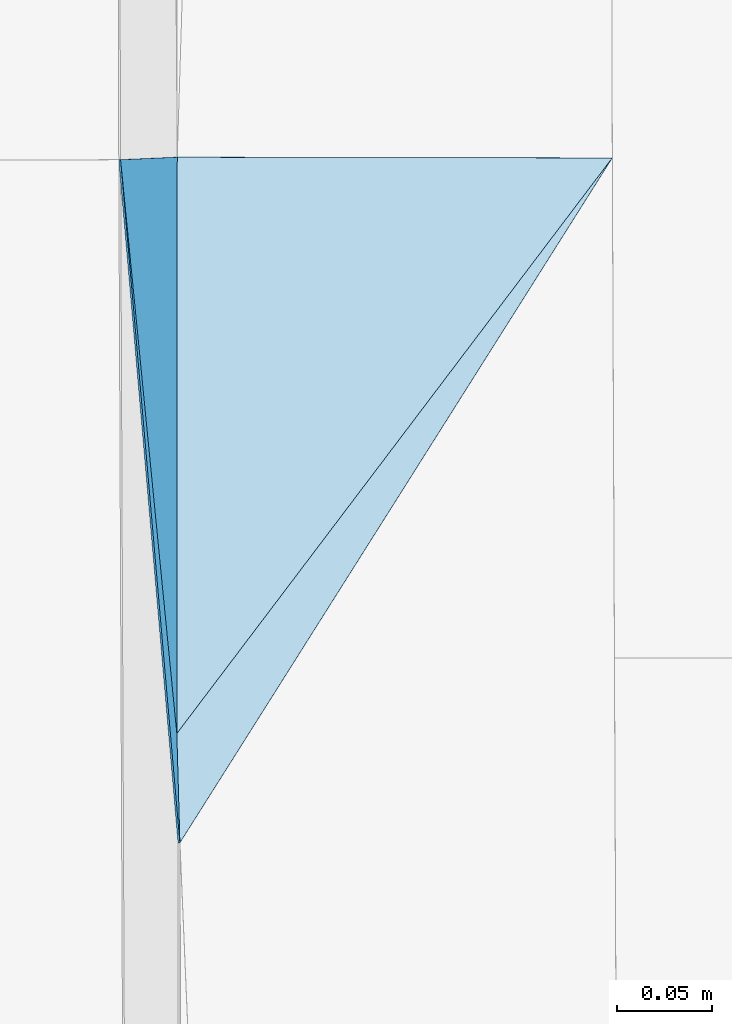
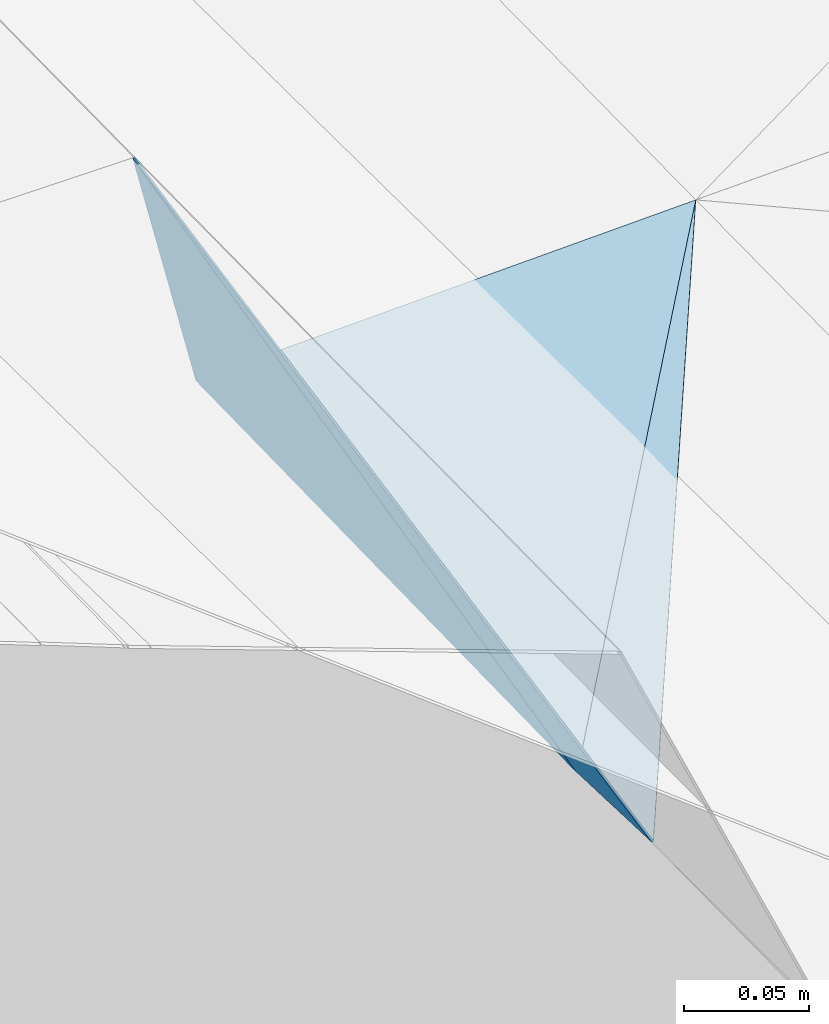
# One storey, part 172 of 275: 4 plates.
"""IFC2X3 building model written with IfcOpenShell, lengths in millimetres."""

import ifcopenshell
import ifcopenshell.guid

model = None  # the IFC model being written
_history = None  # IfcOwnerHistory: only IFC2X3 demands one
_inside = {}  # id of a spatial element -> (the spatial element, [elements in it])
_under = {}  # id of a project, library or spatial element -> (it, [spatial elements below it])
_declared = {}  # id of a project -> (the project, [libraries it declares])
_typed = {}  # id of a type object -> (the type object, [elements of that type])
_made_of = {}  # id of a material, layer set ... -> (it, [elements and type objects made of it])


def new_model(schema):
    """Start an empty IFC model of exactly this schema.

    Asked for "IFC4X3", IfcOpenShell would pick the latest addendum, in which some entities
    have other attributes; the version numbers below select the first issue.
    IFC2X3 requires an IfcOwnerHistory on every rooted entity: one is made here for all.
    """
    global model, _history
    if schema == "IFC4X3":
        model = ifcopenshell.file(schema_version=(4, 3, 0, 0))
    else:
        model = ifcopenshell.file(schema=schema)
    _inside.clear()
    _under.clear()
    _declared.clear()
    _typed.clear()
    _made_of.clear()
    _history = None
    if model.schema == "IFC2X3":
        org = make("IfcOrganization", Name="unknown")
        user = make(
            "IfcPersonAndOrganization",
            ThePerson=make("IfcPerson", FamilyName="unknown"),
            TheOrganization=org,
        )
        app = make(
            "IfcApplication",
            ApplicationDeveloper=org,
            Version="unknown",
            ApplicationFullName="unknown",
            ApplicationIdentifier="unknown",
        )
        _history = make(
            "IfcOwnerHistory",
            OwningUser=user,
            OwningApplication=app,
            ChangeAction="ADDED",
            CreationDate=0,
        )
    return model


def make(cls, **values):
    """One entity of the class cls with the attributes given. An attribute that is None is left unset."""
    return model.create_entity(
        cls, **{name: value for name, value in values.items() if value is not None}
    )


def rooted(cls, **values):
    """An entity with a GlobalId (a new one), such as an element, a storey or a relation."""
    return make(cls, GlobalId=ifcopenshell.guid.new(), OwnerHistory=_history, **values)


def si_unit(unit_type, name, prefix=None):
    """IfcSIUnit, for example si_unit("LENGTHUNIT", "METRE", prefix="MILLI")."""
    return make("IfcSIUnit", UnitType=unit_type, Prefix=prefix, Name=name)


def assignment(units):
    """IfcUnitAssignment: the units of a project."""
    return None if units is None else make("IfcUnitAssignment", Units=units)


def point(xyz):
    """IfcCartesianPoint."""
    return None if xyz is None else make("IfcCartesianPoint", Coordinates=xyz)


def direction(xyz):
    """IfcDirection."""
    return None if xyz is None else make("IfcDirection", DirectionRatios=xyz)


def frame(location, z_axis=None, x_axis=None):
    """IfcAxis2Placement3D, a coordinate frame: its origin and axes. An axis left out is left unset."""
    return make(
        "IfcAxis2Placement3D",
        Location=point(location),
        Axis=direction(z_axis),
        RefDirection=direction(x_axis),
    )


def origin_with_axes():
    """The frame at (0, 0, 0) with the z axis (0, 0, 1) and the x axis (1, 0, 0) written out."""
    return frame((0.0, 0.0, 0.0), z_axis=(0.0, 0.0, 1.0), x_axis=(1.0, 0.0, 0.0))


def place(relative_to, where):
    """IfcLocalPlacement: puts the frame where relative to a parent placement (None: the world)."""
    return make(
        "IfcLocalPlacement", PlacementRelTo=relative_to, RelativePlacement=where
    )


def context(
    kind, dimensions, precision=None, world=None, true_north=None, identifier=None
):
    """IfcGeometricRepresentationContext, for example the 3D "Model" context."""
    return make(
        "IfcGeometricRepresentationContext",
        ContextIdentifier=identifier,
        ContextType=kind,
        CoordinateSpaceDimension=dimensions,
        Precision=precision,
        WorldCoordinateSystem=world,
        TrueNorth=true_north,
    )


def subcontext(parent, identifier, kind, view, scale=None):
    """IfcGeometricRepresentationSubContext, for example "Body" below "Model"."""
    return make(
        "IfcGeometricRepresentationSubContext",
        ContextIdentifier=identifier,
        ContextType=kind,
        ParentContext=parent,
        TargetScale=scale,
        TargetView=view,
    )


def project(units=None, contexts=None):
    """IfcProject with its units and contexts."""
    return rooted(
        "IfcProject",
        Name="project",
        RepresentationContexts=contexts,
        UnitsInContext=assignment(units),
    )


def spatial(cls, under=None, at=None, **own):
    """A site, building, storey or space (cls), placed at a placement, below another one or the project."""
    s = rooted(cls, ObjectPlacement=at, **own)
    if under is not None:
        _under.setdefault(under.id(), (under, []))[1].append(s)
    return s


def polyline(points):
    """IfcPolyline through the points."""
    return make("IfcPolyline", Points=[point(p) for p in points])


def outline(outer, holes=None, kind="AREA"):
    """IfcArbitraryClosedProfileDef: a profile drawn as a closed curve; with holes, ...WithVoids."""
    if holes is None:
        return make("IfcArbitraryClosedProfileDef", ProfileType=kind, OuterCurve=outer)
    return make(
        "IfcArbitraryProfileDefWithVoids",
        ProfileType=kind,
        OuterCurve=outer,
        InnerCurves=holes,
    )


def extrude(swept, where, along, depth):
    """IfcExtrudedAreaSolid: the profile swept, set in the frame where, extruded along a direction by depth."""
    return make(
        "IfcExtrudedAreaSolid",
        SweptArea=swept,
        Position=where,
        ExtrudedDirection=direction(along),
        Depth=depth,
    )


def shape(context_of_items, identifier, shape_type, items):
    """IfcShapeRepresentation: the items that make up one representation, for example the "Body"."""
    return make(
        "IfcShapeRepresentation",
        ContextOfItems=context_of_items,
        RepresentationIdentifier=identifier,
        RepresentationType=shape_type,
        Items=items,
    )


def material(Name=None, Category=None):
    """IfcMaterial."""
    return make("IfcMaterial", Name=Name, Category=Category)


def made_of(thing, what):
    """Note that an element or type object is made of a material, layer set ...; save() writes the relation."""
    if what is not None:
        _made_of.setdefault(what.id(), (what, []))[1].append(thing)
    return thing


def type_object(cls, material=None, **own):
    """A type object (cls), such as IfcWallType, which elements share."""
    return made_of(rooted(cls, **own), material)


def element(
    cls,
    number,
    at=None,
    inside=None,
    cuts=None,
    type_object=None,
    material=None,
    context=None,
    identifier="Body",
    shape_type=None,
    held_by="IfcProductDefinitionShape",
    body=None,
    shapes=None,
    **own,
):
    """One element of the class cls, such as IfcWall. Its Tag is "e" and its number.

    at: its placement. inside: the storey or other place that contains it. cuts: it is an
    opening in that element (IfcRelVoidsElement). A single representation is given by context,
    identifier, shape_type and body (its items); several are given by shapes. held_by: the class
    of the entity that holds the representations. save() writes the other relations.
    """
    e = rooted(cls, Tag="e%d" % number, ObjectPlacement=at, **own)
    if body is not None:
        shapes = [shape(context, identifier, shape_type, body)]
    if shapes is not None:
        e.Representation = make(held_by, Representations=shapes)
    if inside is not None:
        _inside.setdefault(inside.id(), (inside, []))[1].append(e)
    if cuts is not None:
        rooted(
            "IfcRelVoidsElement", RelatingBuildingElement=cuts, RelatedOpeningElement=e
        )
    if type_object is not None:
        _typed.setdefault(type_object.id(), (type_object, []))[1].append(e)
    return made_of(e, material)


def aggregate(whole, parts):
    """IfcRelAggregates: a whole, such as a stair, and the parts it consists of."""
    return rooted("IfcRelAggregates", RelatingObject=whole, RelatedObjects=parts)


def save(model, path):
    """Write the relations noted so far, then the file.

    IfcRelAggregates (storeys below a building ...), IfcRelContainedInSpatialStructure (elements
    in a storey), IfcRelDefinesByType, IfcRelAssociatesMaterial and IfcRelDeclares: one each for
    every whole, place, type object, material and project.
    """
    for whole, parts in _under.values():
        aggregate(whole, parts)
    for where, things in _inside.values():
        rooted(
            "IfcRelContainedInSpatialStructure",
            RelatedElements=things,
            RelatingStructure=where,
        )
    for kind, things in _typed.values():
        rooted("IfcRelDefinesByType", RelatedObjects=things, RelatingType=kind)
    for what, things in _made_of.values():
        rooted("IfcRelAssociatesMaterial", RelatedObjects=things, RelatingMaterial=what)
    for by, libraries in _declared.values():
        rooted("IfcRelDeclares", RelatingContext=by, RelatedDefinitions=libraries)
    model.write(path)


model = new_model("IFC2X3")

# Units and contexts
model_context = context("Model", 3, precision=1e-05, world=origin_with_axes())
body_context = subcontext(model_context, "Body", "Model", "MODEL_VIEW")
ifc_project = project(units=[si_unit("LENGTHUNIT", "METRE", prefix="MILLI"), si_unit("AREAUNIT", "SQUARE_METRE"), si_unit("VOLUMEUNIT", "CUBIC_METRE"), si_unit("MASSUNIT", "GRAM", prefix="KILO"), si_unit("TIMEUNIT", "SECOND"), si_unit("PLANEANGLEUNIT", "RADIAN"), si_unit("SOLIDANGLEUNIT", "STERADIAN"), si_unit("THERMODYNAMICTEMPERATUREUNIT", "DEGREE_CELSIUS"), si_unit("LUMINOUSINTENSITYUNIT", "LUMEN")], contexts=[model_context])

# Site, building, storey
site_placement = place(None, origin_with_axes())
site = spatial("IfcSite", under=ifc_project, at=site_placement, CompositionType="ELEMENT")
building_placement = place(site_placement, origin_with_axes())
building = spatial("IfcBuilding", under=site, at=building_placement, Name="Undefined", CompositionType="ELEMENT")
storey_placement = place(building_placement, origin_with_axes())
storey = spatial("IfcBuildingStorey", under=building, at=storey_placement, Name="Undefined", CompositionType="ELEMENT", Elevation=0.0)

# Plates
ifc_material = material()
plate_type_1 = type_object("IfcPlateType", PredefinedType="NOTDEFINED")
plate_1_placement = place(storey_placement, frame((-94084.0852699992, 60556.9700525218, 42156.329369753), z_axis=(0.0326111334201583, 0.0203220163660362, -0.999261492116989), x_axis=(0.999467690544892, -0.00158507787642222, 0.0325856269693406)))
element("IfcPlate", 1, at=plate_1_placement, inside=storey, type_object=plate_type_1, material=ifc_material, Name="00_PR", context=body_context, shape_type="SweptSolid", body=[
    extrude(outline(polyline([(0.0, 0.0), (230.162826538086, -1.33150024339557e-09), (0.0537739507853985, 304.807037353516), (0.0, 0.0)])), frame((-8.85201319254618e-08, 2.18876761149539e-07, -0.5000001331573), z_axis=(0.0, 0.0, 1.0), x_axis=(1.0, 0.0, 0.0)), (0.0, 0.0, 1.0), 1.0),
])
plate_type_2 = type_object("IfcPlateType", PredefinedType="NOTDEFINED")
plate_2_placement = place(storey_placement, frame((-94083.1950409793, 60194.4055254666, 42150.5291950197), z_axis=(-0.985801807949787, -0.0277100365074397, -0.165610836963306), x_axis=(-0.0816792010925584, 0.940871180842096, 0.328770328907098)))
element("IfcPlate", 2, at=plate_2_placement, inside=storey, type_object=plate_type_2, material=ifc_material, Name="00_PR", context=body_context, shape_type="SweptSolid", body=[
    extrude(outline(polyline([(0.0, 0.0), (383.906311035156, -1.20780896395445e-09), (54.5160636901855, 19.264066696167), (0.0, 0.0)])), frame((-8.85201319254618e-08, 2.18876761149539e-07, -0.5000001331573), z_axis=(0.0, 0.0, 1.0), x_axis=(1.0, 0.0, 0.0)), (0.0, 0.0, 1.0), 1.0),
])
plate_type_3 = type_object("IfcPlateType", PredefinedType="NOTDEFINED")
plate_3_placement = place(storey_placement, frame((-93854.0327525101, 60556.5959712621, 42163.8298148959), z_axis=(0.057025318448727, 0.00181220781382018, -0.998371087801856), x_axis=(-0.533549753586521, -0.845162733570098, -0.0320095959375168)))
element("IfcPlate", 3, at=plate_3_placement, inside=storey, type_object=plate_type_3, material=ifc_material, Name="00_PR", context=body_context, shape_type="SweptSolid", body=[
    extrude(outline(polyline([(0.0, 0.0), (428.527740478516, -2.09547579288483e-09), (380.547637939453, 32.2647438049316), (0.0, 0.0)])), frame((-8.85201319254618e-08, 2.18876761149539e-07, -0.5000001331573), z_axis=(0.0, 0.0, 1.0), x_axis=(1.0, 0.0, 0.0)), (0.0, 0.0, 1.0), 1.0),
])
plate_type_4 = type_object("IfcPlateType", PredefinedType="NOTDEFINED")
plate_4_placement = place(storey_placement, frame((-94084.8138847774, 60252.218913866, 42150.5029247694), z_axis=(-0.970222135101887, 0.00565385292338536, -0.242150867240769), x_axis=(-0.0901053230987744, 0.919553986744413, 0.382493785847198)))
element("IfcPlate", 4, at=plate_4_placement, inside=storey, type_object=plate_type_4, material=ifc_material, Name="00_PR", context=body_context, shape_type="SweptSolid", body=[
    extrude(outline(polyline([(0.0, 0.0), (329.953063964844, 3.85625753551722e-10), (282.581268310547, 114.259170532227), (0.0, 0.0)])), frame((-8.85201319254618e-08, 2.18876761149539e-07, -0.5000001331573), z_axis=(0.0, 0.0, 1.0), x_axis=(1.0, 0.0, 0.0)), (0.0, 0.0, 1.0), 1.0),
])

save(model, "model.ifc")
